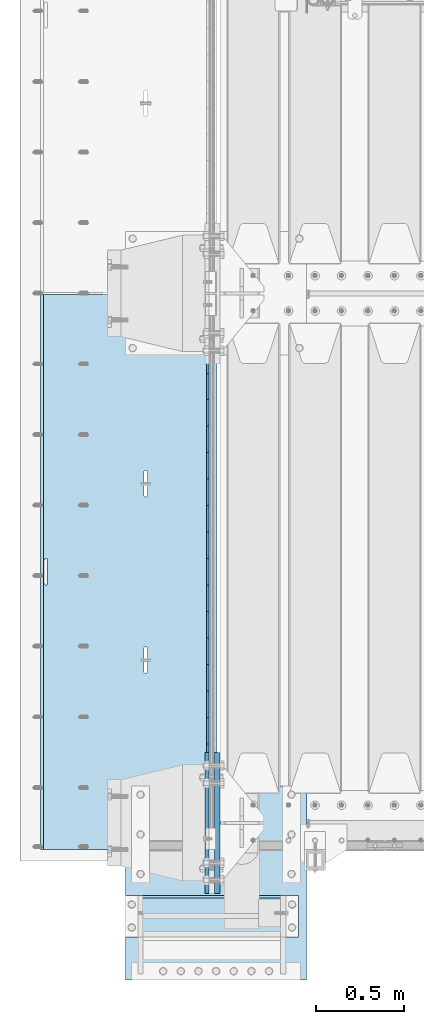
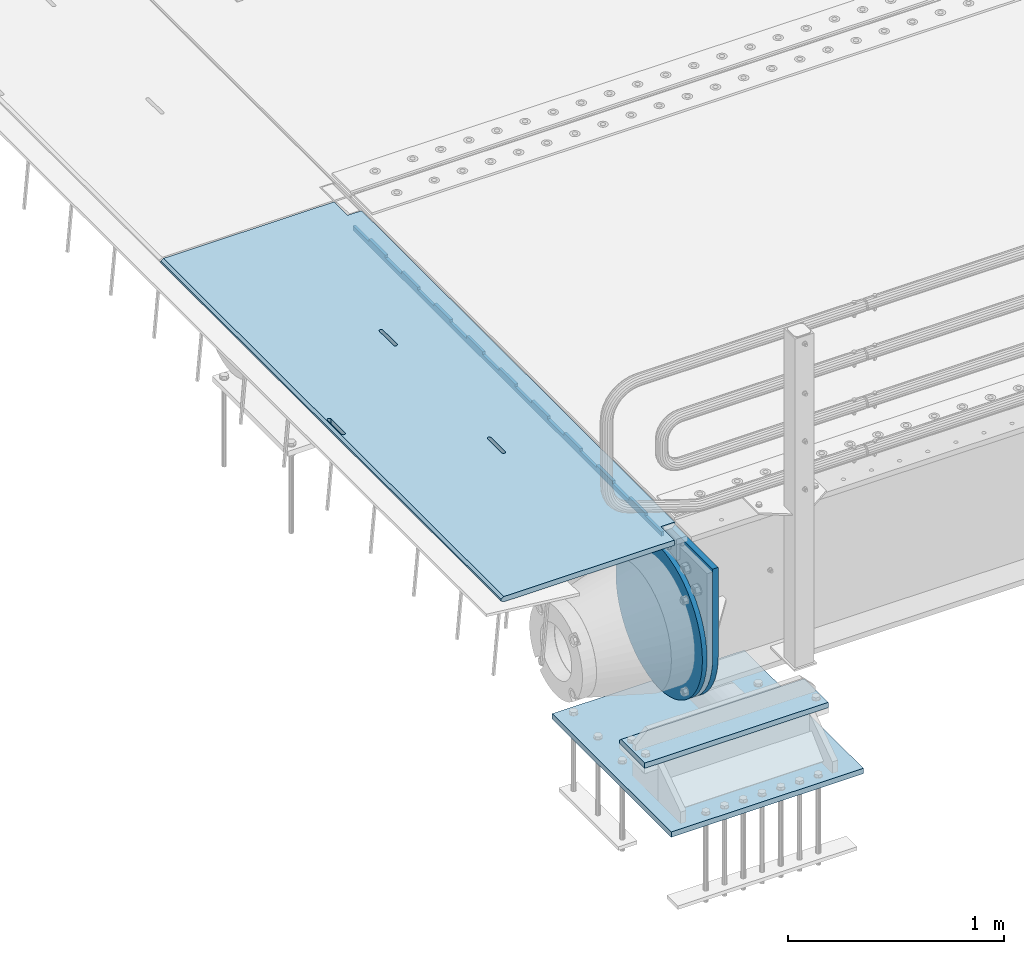
# One storey, part 149 of 193: 6 plates.
"""IFC2X3 building model written with IfcOpenShell, lengths in millimetres."""

from ifc_helpers import new_model, si_unit, frame, origin_with_axes, place, context, subcontext, project, spatial, faceted_brep, material, type_object, element, save


model = new_model("IFC2X3")

# Units and contexts
model_context = context("Model", 3, precision=1e-05, world=origin_with_axes())
body_context = subcontext(model_context, "Body", "Model", "MODEL_VIEW")
ifc_project = project(units=[si_unit("LENGTHUNIT", "METRE", prefix="MILLI"), si_unit("AREAUNIT", "SQUARE_METRE"), si_unit("VOLUMEUNIT", "CUBIC_METRE"), si_unit("MASSUNIT", "GRAM", prefix="KILO"), si_unit("TIMEUNIT", "SECOND"), si_unit("PLANEANGLEUNIT", "RADIAN"), si_unit("SOLIDANGLEUNIT", "STERADIAN"), si_unit("THERMODYNAMICTEMPERATUREUNIT", "DEGREE_CELSIUS"), si_unit("LUMINOUSINTENSITYUNIT", "LUMEN")], contexts=[model_context])

# Site, building, storey
site_placement = place(None, origin_with_axes())
site = spatial("IfcSite", under=ifc_project, at=site_placement, CompositionType="ELEMENT")
building_placement = place(site_placement, origin_with_axes())
building = spatial("IfcBuilding", under=site, at=building_placement, Name="Standard", CompositionType="ELEMENT")
storey_placement = place(building_placement, origin_with_axes())
storey = spatial("IfcBuildingStorey", under=building, at=storey_placement, Name="Undefined", CompositionType="ELEMENT", Elevation=0.0)

# Plates
ifc_material_1 = material(Name="STEEL/S355N")
plate_type_1 = type_object("IfcPlateType", PredefinedType="NOTDEFINED")
plate_1_placement = place(storey_placement, frame((-42455.0037545707, 26994.9999261293, -0.984410850183148), z_axis=(1.0000003385235e-09, -0.999999999987744, -4.95099999993936e-06), x_axis=(-0.999999999879068, -1.00000022173606e-09, -1.55519999981193e-05)))
element("IfcPlate", 1, at=plate_1_placement, inside=storey, type_object=plate_type_1, material=ifc_material_1, context=body_context, shape_type="Brep", body=[
    faceted_brep([(984.99645996136, -15.0, 3.63797880709171e-12), (999.996459960938, -4.99999999999848, 0.0), (999.996459718786, -4.99999999999849, 3145.0), (984.996459719208, -15.0, 3145.0), (999.996459960938, 5.0, 0.0), (984.996459960945, 15.0, 3.63797880709171e-12), (984.996459718794, 15.0, 3145.0), (999.996459718786, 5.0, 3145.0), (14.9998601691696, 15.0, 125.00002482082), (-0.000294611323624849, -0.000806902962788181, 124.99993624862), (-0.00191941575758392, 0.000806844426834874, 3020.00000492302), (14.9966216875182, 15.0, 3020.0000797665), (394.996621756989, -15.0000000032171, 2137.49999999762), (394.996621756989, 15.0, 2137.49999999762), (395.4860565938, 15.0, 2140.59016994137), (395.4860565938, -15.0000000032097, 2140.59016994137), (396.906451812785, 15.0, 2143.37785252055), (396.906451812785, -15.0000000031847, 2143.37785252055), (399.118769233435, 15.0, 2145.59016994137), (399.118769233435, -15.0000000031445, 2145.59016994137), (401.906451812494, 15.0, 2147.01056516057), (401.906451812501, -15.0000000030931, 2147.01056516058), (404.996621756211, 15.0, 2147.49999999762), (404.996621756211, -15.0000000030354, 2147.49999999762), (408.086791699992, 15.0, 2147.01056516057), (408.086791699992, -15.0000000029771, 2147.01056516058), (410.874474279284, 15.0, 2145.59016994137), (410.874474279277, -15.000000002924, 2145.59016994137), (413.086791700283, 15.0, 2143.37785252055), (413.086791700283, -15.0000000028812, 2143.37785252055), (414.507186919691, 15.0, 2140.59016994136), (414.507186919698, -15.000000002853, 2140.59016994136), (414.996621756974, 15.0, 2137.49999999761), (414.996621756974, -15.000000002842, 2137.49999999761), (414.996621766892, 15.0, 2007.49999999761), (414.996621766892, -15.0000000027658, 2007.49999999761), (414.507186930081, 15.0, 2004.40983005386), (414.507186930088, -15.0000000027732, 2004.40983005387), (413.086791711095, 15.0, 2001.62214747469), (413.086791711088, -15.0000000027982, 2001.6221474747), (410.874474290438, 15.0, 1999.40983005387), (410.874474290431, -15.0000000028384, 1999.40983005387), (408.086791711372, 15.0, 1997.98943483467), (408.086791711372, -15.0000000028898, 1997.98943483467), (404.996621767779, 15.0, 1997.49999999762), (404.996621767779, -15.0000000029475, 1997.49999999762), (401.906451823983, 15.0, 1997.98943483467), (401.90645182399, -15.0000000030057, 1997.98943483468), (399.118769244698, 15.0, 1999.40983005387), (399.118769244706, -15.0000000030589, 1999.40983005387), (396.906451823714, 15.0, 2001.6221474747), (396.906451823714, -15.0000000031016, 2001.6221474747), (395.486056604299, 15.0, 2004.40983005387), (395.486056604299, -15.0000000031299, 2004.40983005387), (394.996621767008, 15.0, 2007.49999999762), (394.996621767008, -15.0000000031409, 2007.49999999762), (-0.000449375176685862, -14.9999999951863, 124.999861417731), (-0.000460362061858177, -15.00000004538, 3019.99993008589), (75.0001087167111, 15.0, 125.000079754089), (74.9996421867036, -15.0, 124.99993008409), (74.9997820616045, -15.0, 3.63797880709171e-12), (75.0002485915975, 15.0, 0.0), (74.9967306510152, 15.0, 3145.0), (74.9962640910162, -15.0, 3145.0), (74.9968705259016, 15.0, 3020.0000798241), (74.9964039659026, -14.999999998652, 3019.9999301541), (395.486056681293, -14.9999999992789, 1004.40983005435), (395.486056681293, 15.0, 1004.40983005435), (394.99662184401, 15.0, 1007.4999999981), (394.99662184401, -14.999999999278, 1007.4999999981), (396.906451900715, -14.999999999282, 1001.62214747518), (396.906451900715, 15.0, 1001.62214747518), (399.118769321707, -14.999999999287, 999.409830054352), (399.1187693217, 15.0, 999.409830054352), (401.906451900999, -14.9999999992934, 997.989434835152), (401.906451900992, 15.0, 997.989434835152), (404.996621844781, -14.9999999993006, 997.499999998101), (404.996621844781, 15.0, 997.499999998101), (408.086791788373, -14.9999999993078, 997.989434835152), (408.086791788373, 15.0, 997.989434835148), (410.87447436744, -14.9999999993143, 999.409830054352), (410.87447436744, 15.0, 999.409830054352), (413.086791788097, -14.9999999993196, 1001.62214747518), (413.086791788097, 15.0, 1001.62214747518), (414.50718700709, -14.999999999323, 1004.40983005435), (414.507187007082, 15.0, 1004.40983005434), (414.996621843893, -14.9999999993243, 1007.49999999809), (414.996621843893, 15.0, 1007.49999999809), (414.996621833976, -14.9999999993318, 1137.49999999809), (414.996621833976, 15.0, 1137.49999999809), (414.507186996707, -14.9999999993308, 1140.59016994184), (414.5071869967, 15.0, 1140.59016994184), (413.086791777278, -14.9999999993277, 1143.37785252103), (413.086791777278, 15.0, 1143.37785252103), (410.874474356286, -14.9999999993227, 1145.59016994185), (410.874474356286, 15.0, 1145.59016994185), (408.086791776994, -14.9999999993163, 1147.01056516106), (408.086791776994, 15.0, 1147.01056516105), (404.996621833212, -14.9999999993092, 1147.4999999981), (404.996621833212, 15.0, 1147.4999999981), (401.90645188951, -14.999999999302, 1147.01056516106), (401.906451889503, 15.0, 1147.01056516106), (399.118769310437, -14.9999999992955, 1145.59016994185), (399.118769310437, 15.0, 1145.59016994185), (396.906451889779, -14.9999999992902, 1143.37785252103), (396.906451889779, 15.0, 1143.37785252103), (395.486056670801, -14.9999999992867, 1140.59016994185), (395.486056670808, 15.0, 1140.59016994185), (394.996621833991, -14.9999999992854, 1137.4999999981), (394.996621833998, 15.0, 1137.4999999981), (960.486056632304, -15.0000000006253, 1640.5901699416), (961.906451851282, -15.0000000006287, 1643.37785252078), (964.118769271947, -15.000000000634, 1645.5901699416), (966.906451851013, -15.0000000006405, 1647.0105651608), (969.996621794708, -15.0000000006477, 1647.49999999785), (973.086791738504, -15.0000000006549, 1647.01056516081), (975.874474317789, -15.0000000006612, 1645.5901699416), (978.08679173878, -15.0000000006662, 1643.37785252077), (979.50718695821, -15.0000000006694, 1640.5901699416), (979.996621795486, -15.0000000006703, 1637.49999999784), (979.996621805396, -15.0000000006628, 1507.49999999784), (979.507186968585, -15.0000000006615, 1504.4098300541), (978.0867917496, -15.0000000006581, 1501.62214747492), (975.874474328943, -15.0000000006528, 1499.4098300541), (973.086791749884, -15.0000000006463, 1497.9894348349), (969.996621806284, -15.0000000006391, 1497.49999999785), (966.906451862502, -15.0000000006319, 1497.9894348349), (964.118769283217, -15.0000000006256, 1499.4098300541), (961.906451862218, -15.0000000006206, 1501.62214747493), (960.486056642796, -15.0000000006174, 1504.4098300541), (959.996621805512, -15.0000000006165, 1507.49999999785), (959.996621795493, -15.000000000624, 1637.49999999785), (961.906451862218, 15.0, 1501.62214747493), (960.486056642796, 15.0, 1504.4098300541), (964.11876928321, 15.0, 1499.4098300541), (966.906451862495, 15.0, 1497.9894348349), (969.996621806284, 15.0, 1497.49999999785), (973.086791749884, 15.0, 1497.9894348349), (975.874474328943, 15.0, 1499.4098300541), (978.0867917496, 15.0, 1501.62214747492), (979.507186968578, 15.0, 1504.4098300541), (979.996621805396, 15.0, 1507.49999999784), (979.996621795486, 15.0, 1637.49999999784), (979.507186958203, 15.0, 1640.5901699416), (978.08679173878, 15.0, 1643.37785252077), (975.874474317789, 15.0, 1645.5901699416), (973.086791738504, 15.0, 1647.01056516081), (969.996621794715, 15.0, 1647.49999999785), (966.906451851006, 15.0, 1647.0105651608), (964.118769271947, 15.0, 1645.5901699416), (961.906451851282, 15.0, 1643.37785252078), (960.486056632304, 15.0, 1640.5901699416), (959.996621795493, 15.0, 1637.49999999785), (959.996621805512, 15.0, 1507.49999999785)], [[[0, 1, 2, 3]], [[4, 5, 6, 7]], [[8, 9, 10, 11]], [[12, 13, 14, 15]], [[15, 14, 16, 17]], [[17, 16, 18, 19]], [[19, 18, 20, 21]], [[21, 20, 22, 23]], [[23, 22, 24, 25]], [[25, 24, 26, 27]], [[27, 26, 28, 29]], [[29, 28, 30, 31]], [[31, 30, 32, 33]], [[33, 32, 34, 35]], [[35, 34, 36, 37]], [[37, 36, 38, 39]], [[39, 38, 40, 41]], [[41, 40, 42, 43]], [[43, 42, 44, 45]], [[45, 44, 46, 47]], [[47, 46, 48, 49]], [[49, 48, 50, 51]], [[51, 50, 52, 53]], [[53, 52, 54, 55]], [[55, 54, 13, 12]], [[56, 57, 10, 9]], [[58, 59, 56, 9, 8]], [[60, 59, 58, 61]], [[60, 61, 5, 4, 1, 0]], [[4, 7, 2, 1]], [[7, 6, 62, 63, 3, 2]], [[63, 62, 64, 65]], [[57, 65, 64, 11, 10]], [[66, 67, 68, 69]], [[70, 71, 67, 66]], [[72, 73, 71, 70]], [[74, 75, 73, 72]], [[76, 77, 75, 74]], [[78, 79, 77, 76]], [[80, 81, 79, 78]], [[82, 83, 81, 80]], [[84, 85, 83, 82]], [[86, 87, 85, 84]], [[88, 89, 87, 86]], [[90, 91, 89, 88]], [[92, 93, 91, 90]], [[94, 95, 93, 92]], [[96, 97, 95, 94]], [[98, 99, 97, 96]], [[100, 101, 99, 98]], [[102, 103, 101, 100]], [[104, 105, 103, 102]], [[106, 107, 105, 104]], [[108, 109, 107, 106]], [[69, 68, 109, 108]], [[63, 65, 57, 56, 59, 60, 0, 3], [15, 17, 19, 21, 23, 25, 27, 29, 31, 33, 35, 37, 39, 41, 43, 45, 47, 49, 51, 53, 55, 12], [106, 104, 102, 100, 98, 96, 94, 92, 90, 88, 86, 84, 82, 80, 78, 76, 74, 72, 70, 66, 69, 108], [110, 111, 112, 113, 114, 115, 116, 117, 118, 119, 120, 121, 122, 123, 124, 125, 126, 127, 128, 129, 130, 131]], [[128, 132, 133, 129]], [[127, 134, 132, 128]], [[126, 135, 134, 127]], [[125, 136, 135, 126]], [[124, 137, 136, 125]], [[123, 138, 137, 124]], [[122, 139, 138, 123]], [[121, 140, 139, 122]], [[120, 141, 140, 121]], [[119, 142, 141, 120]], [[118, 143, 142, 119]], [[117, 144, 143, 118]], [[116, 145, 144, 117]], [[115, 146, 145, 116]], [[114, 147, 146, 115]], [[113, 148, 147, 114]], [[112, 149, 148, 113]], [[111, 150, 149, 112]], [[110, 151, 150, 111]], [[131, 152, 151, 110]], [[130, 153, 152, 131]], [[129, 133, 153, 130]], [[61, 58, 8, 11, 64, 62, 6, 5], [50, 48, 46, 44, 42, 40, 38, 36, 34, 32, 30, 28, 26, 24, 22, 20, 18, 16, 14, 13, 54, 52], [132, 134, 135, 136, 137, 138, 139, 140, 141, 142, 143, 144, 145, 146, 147, 148, 149, 150, 151, 152, 153, 133], [71, 73, 75, 77, 79, 81, 83, 85, 87, 89, 91, 93, 95, 97, 99, 101, 103, 105, 107, 109, 68, 67]]]),
])
plate_type_2 = type_object("IfcPlateType", PredefinedType="NOTDEFINED")
plate_2_placement = place(storey_placement, frame((-42507.5, 26847.5000993725, -35.9858217390411), z_axis=(1.0000003385235e-09, -0.999999999987744, -4.95099999993936e-06), x_axis=(0.0, 4.95100000930962e-06, -0.999999999987744)))
element("IfcPlate", 2, at=plate_2_placement, inside=storey, type_object=plate_type_2, material=ifc_material_1, context=body_context, shape_type="Brep", body=[
    faceted_brep([(0.0, -7.5, -3.63797880709171e-12), (8.68993765834603e-12, -7.5, 150.0), (8.68993765834603e-12, 7.5, 150.0), (0.0, 7.5, -3.63797880709171e-12), (-14.9999999999986, -7.5, 149.999999999996), (-14.9999999999986, 7.5, 149.999999999996), (-14.9999999999972, -7.5, 300.0), (-14.9999999999972, 7.5, 300.0), (1.55395696310734e-11, -7.5, 300.0), (1.55395696310734e-11, 7.5, 300.0), (1.87725390787818e-11, -7.5, 449.999999999996), (1.87725390787818e-11, 7.5, 449.999999999996), (-14.9999999999958, -7.5, 449.999999999996), (-14.9999999999958, 7.5, 449.999999999996), (-14.9999999999944, -7.5, 599.999999999996), (-14.9999999999944, 7.5, 599.999999999996), (2.74553713097703e-11, -7.5, 600.0), (2.74553713097703e-11, 7.5, 600.0), (3.24931193063094e-11, -7.5, 750.0), (3.24931193063094e-11, 7.5, 750.0), (-14.999999999993, -7.5, 750.0), (-14.999999999993, 7.5, 750.0), (-14.9999999999916, -7.5, 900.0), (-14.9999999999916, 7.5, 900.0), (4.11830569646554e-11, -7.5, 899.999999999996), (4.11830569646554e-11, 7.5, 899.999999999996), (4.62208049611945e-11, -7.5, 1050.0), (4.62208049611945e-11, 7.5, 1050.0), (-14.9999999999902, -7.5, 1050.0), (-14.9999999999902, 7.5, 1050.0), (-14.9999999999888, -7.5, 1200.0), (-14.9999999999888, 7.5, 1200.0), (5.30917532159947e-11, -7.5, 1200.0), (5.30917532159947e-11, 7.5, 1200.0), (5.99484906160797e-11, -7.5, 1350.0), (5.99484906160797e-11, 7.5, 1350.0), (-14.9999999999873, -7.5, 1350.0), (-14.9999999999873, 7.5, 1350.0), (-14.9999999999859, -7.5, 1500.0), (-14.9999999999859, 7.5, 1500.0), (6.49933440399764e-11, -7.5, 1500.0), (6.49933440399764e-11, 7.5, 1500.0), (7.36761762709648e-11, -7.5, 1650.0), (7.36761762709648e-11, 7.5, 1650.0), (-14.9999999999845, -7.5, 1650.0), (-14.9999999999845, 7.5, 1650.0), (-14.9999999999831, -7.5, 1800.0), (-14.9999999999831, 7.5, 1800.0), (7.6894934863958e-11, -7.5, 1800.0), (7.6894934863958e-11, 7.5, 1800.0), (8.37587776914006e-11, -7.5, 1950.0), (8.37587776914006e-11, 7.5, 1950.0), (-14.9999999999817, -7.5, 1950.0), (-14.9999999999817, 7.5, 1950.0), (-14.9999999999803, -7.5, 2100.0), (-14.9999999999803, 7.5, 2100.0), (9.06297259462008e-11, -7.5, 2100.0), (9.06297259462008e-11, 7.5, 2100.0), (9.56674739427399e-11, -7.5, 2250.0), (9.56674739427399e-11, 7.5, 2250.0), (-14.9999999999789, -7.5, 2250.0), (-14.9999999999789, 7.5, 2250.0), (-14.9999999999775, -7.5, 2400.0), (-14.9999999999775, 7.5, 2400.0), (1.04350306173728e-10, -7.5, 2400.0), (1.04350306173728e-10, 7.5, 2400.0), (1.09388054170267e-10, -7.5, 2550.0), (1.09388054170267e-10, 7.5, 2550.0), (-14.9999999999761, -7.5, 2550.0), (-14.9999999999761, 7.5, 2550.0), (-14.9999999999747, -7.5, 2700.0), (-14.9999999999747, 7.5, 2700.0), (1.14440013021522e-10, -7.5, 2700.0), (1.14440013021522e-10, 7.5, 2700.0), (1.23115739825153e-10, -7.5, 2850.0), (1.23115739825153e-10, 7.5, 2850.0), (25.0000000000267, -7.5, 2850.0), (25.0000000000267, 7.5, 2850.0), (25.0, -7.5, -3.63797880709171e-12), (25.0, 7.5, -3.63797880709171e-12)], [[[0, 1, 2, 3]], [[1, 4, 5, 2]], [[4, 6, 7, 5]], [[6, 8, 9, 7]], [[8, 10, 11, 9]], [[10, 12, 13, 11]], [[12, 14, 15, 13]], [[14, 16, 17, 15]], [[16, 18, 19, 17]], [[18, 20, 21, 19]], [[20, 22, 23, 21]], [[22, 24, 25, 23]], [[24, 26, 27, 25]], [[26, 28, 29, 27]], [[28, 30, 31, 29]], [[30, 32, 33, 31]], [[32, 34, 35, 33]], [[34, 36, 37, 35]], [[36, 38, 39, 37]], [[38, 40, 41, 39]], [[40, 42, 43, 41]], [[42, 44, 45, 43]], [[44, 46, 47, 45]], [[46, 48, 49, 47]], [[48, 50, 51, 49]], [[50, 52, 53, 51]], [[52, 54, 55, 53]], [[54, 56, 57, 55]], [[56, 58, 59, 57]], [[58, 60, 61, 59]], [[60, 62, 63, 61]], [[62, 64, 65, 63]], [[64, 66, 67, 65]], [[66, 68, 69, 67]], [[68, 70, 71, 69]], [[70, 72, 73, 71]], [[72, 74, 75, 73]], [[74, 76, 77, 75]], [[76, 78, 79, 77]], [[78, 0, 3, 79]], [[5, 7, 9, 11, 13, 15, 17, 19, 21, 23, 25, 27, 29, 31, 33, 35, 37, 39, 41, 43, 45, 47, 49, 51, 53, 55, 57, 59, 61, 63, 65, 67, 69, 71, 73, 75, 77, 79, 3, 2]], [[78, 76, 74, 72, 70, 68, 66, 64, 62, 60, 58, 56, 54, 52, 50, 48, 46, 44, 42, 40, 38, 36, 34, 32, 30, 28, 26, 24, 22, 20, 18, 16, 14, 12, 10, 8, 6, 4, 1, 0]]]),
])
ifc_material_2 = material()
plate_type_3 = type_object("IfcPlateType", PredefinedType="NOTDEFINED")
plate_3_placement = place(storey_placement, frame((-41995.0, 23355.0, -803.000000000004), z_axis=(0.0, 1.0, 0.0), x_axis=(-1.0, 0.0, 0.0)))
element("IfcPlate", 3, at=plate_3_placement, inside=storey, type_object=plate_type_3, material=ifc_material_2, context=body_context, shape_type="Brep", body=[
    faceted_brep([(979.0, 0.0, 235.0), (979.0, 15.0, 220.0), (0.0, 15.0, 220.0), (0.0, 0.0, 235.0), (0.0, 15.0, 0.0), (0.0, -15.0, 0.0), (0.0, -15.0, 235.0), (979.0, -15.0, 235.0), (979.0, -15.0, 0.0), (979.0, 15.0, 0.0)], [[[0, 1, 2, 3]], [[4, 5, 6, 3, 2]], [[6, 7, 0, 3]], [[7, 8, 9, 1, 0]], [[8, 5, 4, 9]], [[9, 4, 2, 1]], [[8, 7, 6, 5]]]),
])
plate_type_4 = type_object("IfcPlateType", PredefinedType="NOTDEFINED")
plate_4_placement = place(storey_placement, frame((-42974.0, 23110.0, -1043.0), z_axis=(1.0, 0.0, 0.0), x_axis=(0.0, 1.0, 0.0)))
element("IfcPlate", 4, at=plate_4_placement, inside=storey, type_object=plate_type_4, material=ifc_material_2, context=body_context, shape_type="Brep", body=[
    faceted_brep([(0.0, -15.0, 0.0), (2.93249104288407e-06, -15.0, 1025.0), (2.93249104288407e-06, 15.0, 1025.0), (0.0, 15.0, 0.0), (1100.0, -15.0, 1025.0), (1100.0, 15.0, 1025.0), (1100.0, -15.0, -2.18278728425503e-11), (1100.0, 15.0, -2.18278728425503e-11)], [[[0, 1, 2, 3]], [[1, 4, 5, 2]], [[4, 6, 7, 5]], [[6, 0, 3, 7]], [[5, 7, 3, 2]], [[6, 4, 1, 0]]]),
])
plate_type_5 = type_object("IfcPlateType", PredefinedType="NOTDEFINED")
plate_5_placement = place(storey_placement, frame((-42512.5, 24400.0, -114.999999999998), z_axis=(0.0, 0.0, -1.0), x_axis=(0.0, -1.0, 0.0)))
element("IfcPlate", 5, at=plate_5_placement, inside=storey, type_object=plate_type_5, material=ifc_material_1, context=body_context, shape_type="Brep", body=[
    faceted_brep([(0.0, -12.5, 400.0), (2.91645036198679, -12.5, 448.214672101512), (2.91645036198679, 12.5, 448.214672101512), (0.0, 12.5, 400.0), (11.6232730309493, -12.5, 495.726265714256), (11.6232730309493, 12.5, 495.726265714256), (25.9935029273365, -12.5, 541.8419548161), (25.9935029273365, 12.5, 541.8419548161), (45.8175897403271, -12.5, 585.889268816449), (45.8175897403271, 12.5, 585.889268816449), (70.8064536442362, -12.5, 627.225898691268), (70.8064536442362, 12.5, 627.225898691268), (100.595700733313, -12.5, 665.249063294999), (100.595700733313, 12.5, 665.249063294999), (134.75093670547, -12.5, 699.404299267018), (134.75093670547, 12.5, 699.404299267018), (172.774101309333, -12.5, 729.193546355957), (172.774101309333, 12.5, 729.193546355957), (214.110731184279, -12.5, 754.182410259709), (214.110731184279, 12.5, 754.182410259709), (258.15804518474, -12.5, 774.006497072558), (258.15804518474, 12.5, 774.006497072558), (304.273734286686, -12.5, 788.3767269688), (304.273734286686, 12.5, 788.3767269688), (351.785327899521, -12.5, 797.08354963762), (351.785327899521, 12.5, 797.08354963762), (400.0, -12.5, 800.0), (400.0, 12.5, 800.0), (448.214672103386, -12.5, 797.083549638417), (448.214672103386, 12.5, 797.083549638417), (495.726265716061, -12.5, 788.376726969676), (495.726265716061, 12.5, 788.376726969676), (541.841954817824, -12.5, 774.006497073486), (541.841954817824, 12.5, 774.006497073486), (585.889268818086, -12.5, 754.182410260677), (585.889268818086, 12.5, 754.182410260677), (627.225898692806, -12.5, 729.193546356939), (627.225898692806, 12.5, 729.193546356939), (665.249063296429, -12.5, 699.404299268001), (665.249063296429, 12.5, 699.404299268001), (699.404299268313, -12.5, 665.249063295971), (699.404299268313, 12.5, 665.249063295971), (729.193546357106, -12.5, 627.225898692217), (729.193546357106, 12.5, 627.225898692217), (754.182410260699, -12.5, 585.889268817373), (754.182410260699, 12.5, 585.889268817373), (774.006497073362, -12.5, 541.841954816995), (774.006497073362, 12.5, 541.841954816995), (788.376726969407, -12.5, 495.72626571513), (788.376726969407, 12.5, 495.72626571513), (797.083549638006, -12.5, 448.214672102371), (797.083549638006, 12.5, 448.214672102371), (800.0, -12.5, 400.0), (800.0, 12.5, 400.0), (797.08354963802, -12.5, 351.785327898502), (797.08354963802, 12.5, 351.785327898502), (788.376726969058, -12.5, 304.273734285758), (788.376726969058, 12.5, 304.273734285758), (774.006497072671, -12.5, 258.158045183915), (774.006497072671, 12.5, 258.158045183915), (754.182410259677, -12.5, 214.110731183569), (754.182410259677, 12.5, 214.110731183569), (729.193546355775, -12.5, 172.774101308751), (729.193546355775, 12.5, 172.774101308751), (699.404299266695, -12.5, 134.750936705022), (699.404299266695, 12.5, 134.750936705022), (665.249063294537, -12.5, 100.595700733003), (665.249063294537, 12.5, 100.595700733003), (627.225898690671, -12.5, 70.8064536440688), (627.225898690671, 12.5, 70.8064536440688), (585.889268815728, -12.5, 45.8175897403125), (585.889268815728, 12.5, 45.8175897403125), (541.841954815267, -12.5, 25.9935029274711), (541.841954815267, 12.5, 25.9935029274711), (495.726265713321, -12.5, 11.6232730312295), (495.726265713321, 12.5, 11.6232730312295), (448.214672100487, -12.5, 2.9164503624088), (448.214672100487, 12.5, 2.9164503624088), (400.0, -12.5, -5.6843418860808e-14), (400.0, 12.5, -5.6843418860808e-14), (351.785327896621, -12.5, 2.91645036159025), (351.785327896621, 12.5, 2.91645036159025), (304.27373428395, -12.5, 11.6232730303345), (304.27373428395, 12.5, 11.6232730303345), (258.158045182186, -12.5, 25.9935029265253), (258.158045182186, 12.5, 25.9935029265253), (214.110731181921, -12.5, 45.8175897393376), (214.110731181921, 12.5, 45.8175897393376), (172.774101307201, -12.5, 70.8064536430757), (172.774101307201, 12.5, 70.8064536430757), (134.750936703582, -12.5, 100.59570073201), (134.750936703582, 12.5, 100.59570073201), (100.595700731694, -12.5, 134.750936704037), (100.595700731694, 12.5, 134.750936704037), (70.8064536429047, -12.5, 172.774101307794), (70.8064536429047, 12.5, 172.774101307794), (45.8175897393085, -12.5, 214.110731182634), (45.8175897393085, 12.5, 214.110731182634), (25.9935029266453, -12.5, 258.158045183012), (25.9935029266453, 12.5, 258.158045183012), (11.6232730306001, -12.5, 304.273734284878), (11.6232730306001, 12.5, 304.273734284878), (2.9164503619977, -12.5, 351.78532789764), (2.9164503619977, 12.5, 351.78532789764)], [[[0, 1, 2, 3]], [[1, 4, 5, 2]], [[4, 6, 7, 5]], [[6, 8, 9, 7]], [[8, 10, 11, 9]], [[10, 12, 13, 11]], [[12, 14, 15, 13]], [[14, 16, 17, 15]], [[16, 18, 19, 17]], [[18, 20, 21, 19]], [[20, 22, 23, 21]], [[22, 24, 25, 23]], [[24, 26, 27, 25]], [[26, 28, 29, 27]], [[28, 30, 31, 29]], [[30, 32, 33, 31]], [[32, 34, 35, 33]], [[34, 36, 37, 35]], [[36, 38, 39, 37]], [[38, 40, 41, 39]], [[40, 42, 43, 41]], [[42, 44, 45, 43]], [[44, 46, 47, 45]], [[46, 48, 49, 47]], [[48, 50, 51, 49]], [[50, 52, 53, 51]], [[52, 54, 55, 53]], [[54, 56, 57, 55]], [[56, 58, 59, 57]], [[58, 60, 61, 59]], [[60, 62, 63, 61]], [[62, 64, 65, 63]], [[64, 66, 67, 65]], [[66, 68, 69, 67]], [[68, 70, 71, 69]], [[70, 72, 73, 71]], [[72, 74, 75, 73]], [[74, 76, 77, 75]], [[76, 78, 79, 77]], [[78, 80, 81, 79]], [[80, 82, 83, 81]], [[82, 84, 85, 83]], [[84, 86, 87, 85]], [[86, 88, 89, 87]], [[88, 90, 91, 89]], [[90, 92, 93, 91]], [[92, 94, 95, 93]], [[94, 96, 97, 95]], [[96, 98, 99, 97]], [[98, 100, 101, 99]], [[100, 102, 103, 101]], [[102, 0, 3, 103]], [[5, 7, 9, 11, 13, 15, 17, 19, 21, 23, 25, 27, 29, 31, 33, 35, 37, 39, 41, 43, 45, 47, 49, 51, 53, 55, 57, 59, 61, 63, 65, 67, 69, 71, 73, 75, 77, 79, 81, 83, 85, 87, 89, 91, 93, 95, 97, 99, 101, 103, 3, 2]], [[102, 100, 98, 96, 94, 92, 90, 88, 86, 84, 82, 80, 78, 76, 74, 72, 70, 68, 66, 64, 62, 60, 58, 56, 54, 52, 50, 48, 46, 44, 42, 40, 38, 36, 34, 32, 30, 28, 26, 24, 22, 20, 18, 16, 14, 12, 10, 8, 6, 4, 1, 0]]]),
])
plate_type_6 = type_object("IfcPlateType", PredefinedType="NOTDEFINED")
plate_6_placement = place(storey_placement, frame((-42455.0, 23600.0, -20.0), z_axis=(0.0, 1.0, 0.0), x_axis=(0.0, 0.0, -1.0)))
element("IfcPlate", 6, at=plate_6_placement, inside=storey, type_object=plate_type_6, material=ifc_material_1, context=body_context, shape_type="Brep", body=[
    faceted_brep([(855.0, -15.0, 572.963114671471), (855.0, 15.0, 572.963114671471), (849.182410261268, 15.0, 585.889268817518), (849.182410261268, -15.0, 585.889268817518), (824.19354635745, 15.0, 627.225898692468), (824.19354635745, -15.0, 627.225898692468), (794.404299268433, 15.0, 665.249063296324), (794.404299268433, -15.0, 665.249063296324), (760.249063296315, 15.0, 699.404299268441), (760.249063296315, -15.0, 699.404299268441), (722.225898692465, 15.0, 729.193546357463), (722.225898692465, -15.0, 729.193546357463), (680.889268817516, 15.0, 754.182410261281), (680.889268817516, -15.0, 754.182410261281), (636.841954817028, 15.0, 774.006497074162), (636.841954817028, -15.0, 774.006497074162), (590.726265715042, 15.0, 788.376726970419), (590.726265715042, -15.0, 788.376726970419), (543.214672102154, 15.0, 797.083549639221), (543.214672102154, -15.0, 797.083549639221), (495.0, -15.0, 800.000000000029), (495.0, 15.0, 800.0), (494.999999999412, -15.0, 0.0), (494.999999999412, 15.0, 0.0), (543.214672102129, 15.0, 2.91645036080809), (543.214672102129, -15.0, 2.91645036080809), (590.726265715023, 15.0, 11.6232730296069), (590.726265715023, -15.0, 11.6232730296069), (636.841954817014, 15.0, 25.9935029258631), (636.841954817014, -15.0, 25.9935029258631), (680.889268817507, 15.0, 45.8175897387446), (680.889268817507, -15.0, 45.8175897387446), (722.225898692462, 15.0, 70.8064536425663), (722.225898692462, -15.0, 70.8064536425663), (760.249063296318, 15.0, 100.595700731588), (760.249063296318, -15.0, 100.595700731588), (794.404299268441, 15.0, 134.750936703713), (794.404299268441, -15.0, 134.750936703713), (824.193546357463, 15.0, 172.774101307568), (824.193546357463, -15.0, 172.774101307568), (849.182410261284, 15.0, 214.110731182522), (849.182410261284, -15.0, 214.110731182522), (855.0, -15.0, 227.036885328536), (855.0, 15.0, 227.036885328536), (0.0, -15.0, 0.0), (0.0, 15.0, 0.0), (0.0, 15.0, 800.0), (0.0, -15.0, 800.0)], [[[0, 1, 2, 3]], [[3, 2, 4, 5]], [[5, 4, 6, 7]], [[7, 6, 8, 9]], [[9, 8, 10, 11]], [[11, 10, 12, 13]], [[13, 12, 14, 15]], [[15, 14, 16, 17]], [[17, 16, 18, 19]], [[20, 19, 18, 21]], [[22, 23, 24, 25]], [[25, 24, 26, 27]], [[27, 26, 28, 29]], [[29, 28, 30, 31]], [[31, 30, 32, 33]], [[33, 32, 34, 35]], [[35, 34, 36, 37]], [[37, 36, 38, 39]], [[39, 38, 40, 41]], [[42, 41, 40, 43]], [[42, 43, 1, 0]], [[44, 45, 23, 22]], [[16, 14, 12, 10, 8, 6, 4, 2, 1, 43, 40, 38, 36, 34, 32, 30, 28, 26, 24, 23, 45, 46, 21, 18]], [[44, 47, 46, 45]], [[46, 47, 20, 21]], [[47, 44, 22, 25, 27, 29, 31, 33, 35, 37, 39, 41, 42, 0, 3, 5, 7, 9, 11, 13, 15, 17, 19, 20]]]),
])

save(model, "model.ifc")
